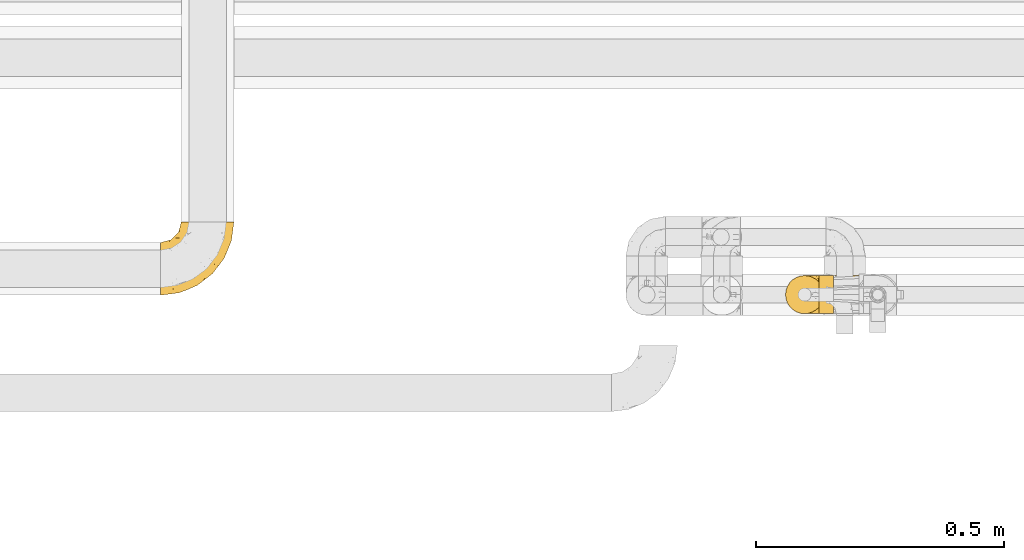
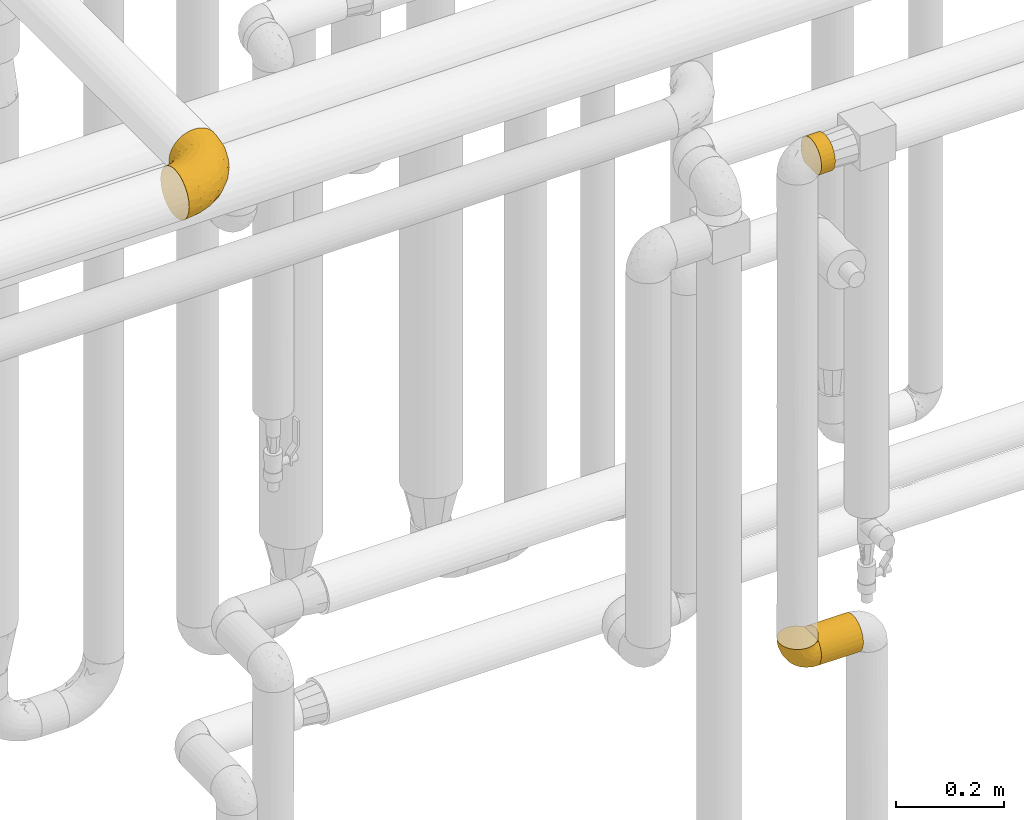
# One storey, part 441 of 827: 4 coverings.
"""IFC2X3 building model written with IfcOpenShell, lengths in millimetres."""

from ifc_helpers import new_model, entity, si_unit, converted_unit, derived_unit, direction, frame, origin, place, context, subcontext, project, spatial, faceted_brep, element, save


model = new_model("IFC2X3")

# Units and contexts
model_context = context("Model", 3, precision=0.01, world=origin(), true_north=direction((6.12303176911189e-17, 1.0)))
body_context = subcontext(model_context, "Body", "Model", "MODEL_VIEW")
ifc_project = project(units=[si_unit("LENGTHUNIT", "METRE", prefix="MILLI"), si_unit("AREAUNIT", "SQUARE_METRE"), si_unit("VOLUMEUNIT", "CUBIC_METRE"), converted_unit("PLANEANGLEUNIT", "DEGREE", entity("IfcRatioMeasure", 0.0174532925199433), si_unit("PLANEANGLEUNIT", "RADIAN"), dimensions=[0, 0, 0, 0, 0, 0, 0]), si_unit("MASSUNIT", "GRAM", prefix="KILO"), derived_unit("MASSDENSITYUNIT", [(si_unit("MASSUNIT", "GRAM", prefix="KILO"), 1), (si_unit("LENGTHUNIT", "METRE"), -3)]), derived_unit("MOMENTOFINERTIAUNIT", [(si_unit("LENGTHUNIT", "METRE"), 4)]), si_unit("TIMEUNIT", "SECOND"), si_unit("FREQUENCYUNIT", "HERTZ"), si_unit("THERMODYNAMICTEMPERATUREUNIT", "DEGREE_CELSIUS"), derived_unit("THERMALTRANSMITTANCEUNIT", [(si_unit("MASSUNIT", "GRAM", prefix="KILO"), 1), (si_unit("THERMODYNAMICTEMPERATUREUNIT", "KELVIN"), -1), (si_unit("TIMEUNIT", "SECOND"), -3)]), derived_unit("VOLUMETRICFLOWRATEUNIT", [(si_unit("LENGTHUNIT", "METRE"), 3), (si_unit("TIMEUNIT", "SECOND"), -1)]), derived_unit("MASSFLOWRATEUNIT", [(si_unit("MASSUNIT", "GRAM", prefix="KILO"), 1), (si_unit("TIMEUNIT", "SECOND"), -1)]), derived_unit("ROTATIONALFREQUENCYUNIT", [(si_unit("TIMEUNIT", "SECOND"), -1)]), si_unit("ELECTRICCURRENTUNIT", "AMPERE"), si_unit("ELECTRICVOLTAGEUNIT", "VOLT"), si_unit("POWERUNIT", "WATT"), si_unit("FORCEUNIT", "NEWTON", prefix="KILO"), si_unit("ILLUMINANCEUNIT", "LUX"), si_unit("LUMINOUSFLUXUNIT", "LUMEN"), si_unit("LUMINOUSINTENSITYUNIT", "CANDELA"), derived_unit("USERDEFINED", [(si_unit("MASSUNIT", "GRAM", prefix="KILO"), -1), (si_unit("LENGTHUNIT", "METRE"), -2), (si_unit("TIMEUNIT", "SECOND"), 3), (si_unit("LUMINOUSFLUXUNIT", "LUMEN"), 1)]), derived_unit("LINEARVELOCITYUNIT", [(si_unit("LENGTHUNIT", "METRE"), 1), (si_unit("TIMEUNIT", "SECOND"), -1)]), si_unit("PRESSUREUNIT", "PASCAL"), derived_unit("USERDEFINED", [(si_unit("LENGTHUNIT", "METRE"), -2), (si_unit("MASSUNIT", "GRAM", prefix="KILO"), 1), (si_unit("TIMEUNIT", "SECOND"), -2)]), derived_unit("LINEARFORCEUNIT", [(si_unit("MASSUNIT", "GRAM", prefix="KILO"), 1), (si_unit("LENGTHUNIT", "METRE"), 1), (si_unit("TIMEUNIT", "SECOND"), -2), (si_unit("LENGTHUNIT", "METRE"), -1)]), derived_unit("PLANARFORCEUNIT", [(si_unit("MASSUNIT", "GRAM", prefix="KILO"), 1), (si_unit("LENGTHUNIT", "METRE"), 1), (si_unit("TIMEUNIT", "SECOND"), -2), (si_unit("LENGTHUNIT", "METRE"), -2)])], contexts=[model_context])

# Site, building, storey
site_placement = place(None, origin())
site = spatial("IfcSite", under=ifc_project, at=site_placement, CompositionType="ELEMENT")
building_placement = place(site_placement, origin())
building = spatial("IfcBuilding", under=site, at=building_placement, CompositionType="ELEMENT")
storey_placement = place(building_placement, frame((0.0, 0.0, 28200.0)))
storey = spatial("IfcBuildingStorey", under=building, at=storey_placement, Name="08", CompositionType="ELEMENT", Elevation=28200.0)

# Coverings
covering_1_placement = place(storey_placement, frame((59220.14, 15404.21, 2660.0)))
element("IfcCovering", 1, at=covering_1_placement, inside=storey, Name=":ADSK_", ObjectType=":ADSK_", PredefinedType="INSULATION", context=body_context, shape_type="Brep", body=[
    faceted_brep([(31.32, 73.25, 20.8), (31.32, 77.09, 30.06), (31.32, 78.4, 40.0), (31.32, 77.09, 49.93), (31.32, 73.25, 59.2), (31.32, 67.15, 67.15), (31.32, 59.2, 73.25), (31.32, 49.93, 77.09), (31.32, 40.0, 78.4), (31.32, 30.06, 77.09), (31.32, 20.8, 73.25), (31.32, 12.84, 67.15), (31.32, 6.74, 59.2), (31.32, 2.9, 49.93), (31.32, 1.6, 40.0), (31.32, 2.9, 30.06), (31.32, 6.74, 20.8), (31.32, 12.84, 12.84), (31.32, 20.8, 6.74), (31.32, 30.06, 2.9), (31.32, 40.0, 1.6), (31.32, 49.93, 2.9), (31.32, 59.2, 6.74), (31.32, 67.15, 12.84), (1.6, 77.09, 49.93), (1.6, 78.4, 40.0), (1.6, 77.51, 31.79), (1.6, 74.9, 23.98), (1.6, 70.68, 16.91), (1.6, 65.05, 10.9), (1.6, 14.94, 10.9), (1.6, 9.31, 16.91), (1.6, 5.09, 23.98), (1.6, 2.48, 31.79), (1.6, 1.6, 40.0), (1.6, 2.9, 49.93), (1.6, 6.74, 59.2), (1.6, 12.84, 67.15), (1.6, 20.8, 73.25), (1.6, 30.06, 77.09), (1.6, 40.0, 78.4), (1.6, 49.93, 77.09), (1.6, 59.2, 73.25), (1.6, 67.15, 67.15), (1.6, 73.25, 59.2), (5.57, 20.48, 6.92), (8.5, 26.63, 4.0), (10.29, 33.21, 2.2), (10.9, 40.0, 1.6), (10.29, 46.78, 2.2), (8.5, 53.36, 4.0), (5.57, 59.51, 6.92)], [[[0, 1, 2, 3, 4, 5, 6, 7, 8, 9, 10, 11, 12, 13, 14, 15, 16, 17, 18, 19, 20, 21, 22, 23]], [[24, 25, 26, 27, 28, 29, 30, 31, 32, 33, 34, 35, 36, 37, 38, 39, 40, 41, 42, 43, 44]], [[14, 34, 33]], [[33, 32, 15]], [[31, 16, 32]], [[14, 33, 15]], [[16, 15, 32]], [[17, 16, 31]], [[31, 30, 17]], [[45, 18, 17]], [[46, 47, 19]], [[45, 46, 18]], [[18, 46, 19]], [[20, 19, 47]], [[48, 20, 47]], [[45, 17, 30]], [[49, 50, 21]], [[22, 51, 23]], [[50, 51, 22]], [[48, 49, 20]], [[20, 49, 21]], [[50, 22, 21]], [[51, 29, 23]], [[0, 28, 27]], [[26, 25, 2]], [[1, 27, 26]], [[23, 28, 0]], [[2, 1, 26]], [[27, 1, 0]], [[28, 23, 29]], [[2, 25, 24, 3]], [[3, 24, 44, 4]], [[4, 44, 43, 5]], [[6, 42, 41, 7]], [[7, 41, 40, 8]], [[5, 43, 42, 6]], [[8, 40, 39, 9]], [[9, 39, 38, 10]], [[10, 38, 37, 11]], [[12, 36, 35, 13]], [[13, 35, 34, 14]], [[11, 37, 36, 12]], [[29, 51, 50, 49, 48, 47, 46, 45, 30]]]),
])
covering_2_placement = place(storey_placement, frame((59220.14, 15404.21, 1553.05)))
element("IfcCovering", 2, at=covering_2_placement, inside=storey, Name=":ADSK_", ObjectType=":ADSK_", PredefinedType="INSULATION", context=body_context, shape_type="Brep", body=[
    faceted_brep([(1.6, 20.8, 6.74), (1.6, 12.84, 12.84), (1.6, 6.74, 20.8), (1.6, 2.9, 30.06), (1.6, 1.6, 40.0), (1.6, 2.48, 48.2), (1.6, 5.09, 56.01), (1.6, 9.31, 63.08), (1.6, 14.94, 69.1), (1.6, 65.05, 69.1), (1.6, 70.68, 63.08), (1.6, 74.9, 56.01), (1.6, 77.51, 48.2), (1.6, 78.4, 40.0), (1.6, 77.09, 30.06), (1.6, 73.25, 20.8), (1.6, 67.15, 12.84), (1.6, 59.2, 6.74), (1.6, 49.93, 2.9), (1.6, 40.0, 1.6), (1.6, 30.06, 2.9), (91.22, 2.9, 49.93), (91.22, 1.6, 40.0), (91.22, 2.48, 31.79), (91.22, 5.09, 23.98), (91.22, 9.31, 16.91), (91.22, 14.94, 10.9), (91.22, 65.05, 10.9), (91.22, 70.68, 16.91), (91.22, 74.9, 23.98), (91.22, 77.51, 31.79), (91.22, 78.4, 40.0), (91.22, 77.09, 49.93), (91.22, 73.25, 59.2), (91.22, 67.15, 67.15), (91.22, 59.2, 73.25), (91.22, 49.93, 77.09), (91.22, 40.0, 78.4), (91.22, 30.06, 77.09), (91.22, 20.8, 73.25), (91.22, 12.84, 67.15), (91.22, 6.74, 59.2), (87.25, 59.51, 6.92), (84.32, 53.36, 4.0), (82.52, 46.78, 2.2), (81.92, 40.0, 1.6), (82.52, 33.21, 2.2), (84.32, 26.63, 4.0), (87.25, 20.48, 6.92), (8.5, 26.63, 76.0), (10.29, 33.21, 77.79), (10.9, 40.0, 78.4), (5.57, 20.48, 73.07), (10.29, 46.78, 77.79), (8.5, 53.36, 76.0), (5.57, 59.51, 73.07)], [[[0, 1, 2, 3, 4, 5, 6, 7, 8, 9, 10, 11, 12, 13, 14, 15, 16, 17, 18, 19, 20]], [[21, 22, 23, 24, 25, 26, 27, 28, 29, 30, 31, 32, 33, 34, 35, 36, 37, 38, 39, 40, 41]], [[31, 30, 13]], [[29, 28, 15]], [[30, 29, 14]], [[14, 13, 30]], [[15, 14, 29]], [[28, 16, 15]], [[28, 27, 16]], [[27, 42, 17]], [[43, 44, 18]], [[42, 43, 17]], [[17, 43, 18]], [[19, 18, 44]], [[45, 19, 44]], [[27, 17, 16]], [[46, 47, 20]], [[48, 26, 0]], [[47, 48, 0]], [[45, 46, 19]], [[19, 46, 20]], [[47, 0, 20]], [[26, 1, 0]], [[2, 25, 24]], [[3, 24, 23]], [[4, 23, 22]], [[1, 25, 2]], [[2, 24, 3]], [[23, 4, 3]], [[25, 1, 26]], [[5, 22, 21]], [[6, 21, 41]], [[7, 41, 40]], [[4, 22, 5]], [[5, 21, 6]], [[41, 7, 6]], [[40, 8, 7]], [[49, 39, 38]], [[38, 37, 50]], [[51, 50, 37]], [[52, 8, 39]], [[50, 49, 38]], [[52, 39, 49]], [[39, 8, 40]], [[53, 51, 37]], [[53, 37, 36]], [[54, 36, 35]], [[54, 53, 36]], [[9, 55, 35]], [[54, 35, 55]], [[35, 34, 9]], [[10, 34, 33]], [[11, 33, 32]], [[12, 32, 31]], [[10, 33, 11]], [[11, 32, 12]], [[31, 13, 12]], [[34, 10, 9]], [[8, 52, 49, 50, 51, 53, 54, 55, 9]], [[44, 43, 42, 27, 26, 48, 47, 46, 45]]]),
])
covering_3_placement = place(storey_placement, frame((59152.59, 15404.16, 1553.0)))
element("IfcCovering", 3, at=covering_3_placement, inside=storey, Name=":ADSK_", ObjectType=":ADSK_", PredefinedType="INSULATION", context=body_context, shape_type="Brep", body=[
    faceted_brep([(23.36, 74.68, 69.15), (16.07, 70.1, 69.15), (9.98, 64.01, 69.15), (5.4, 56.72, 69.15), (2.56, 48.6, 69.15), (1.6, 40.05, 69.15), (2.56, 31.49, 69.15), (5.41, 23.36, 69.15), (9.99, 16.07, 69.15), (16.08, 9.98, 69.15), (23.37, 5.4, 69.15), (31.49, 2.56, 69.15), (40.05, 1.6, 69.15), (48.15, 2.46, 69.15), (55.88, 5.01, 69.15), (62.9, 9.13, 69.15), (68.89, 14.62, 69.15), (68.89, 16.82, 69.15), (68.89, 18.56, 69.15), (68.89, 20.52, 69.15), (68.89, 22.49, 69.15), (68.89, 24.46, 69.15), (68.89, 26.42, 69.15), (68.89, 28.39, 69.15), (68.89, 30.36, 69.15), (68.89, 32.55, 69.15), (68.89, 34.75, 69.15), (68.89, 36.94, 69.15), (68.89, 39.13, 69.15), (68.89, 41.33, 69.15), (68.89, 43.52, 69.15), (68.89, 45.72, 69.15), (68.89, 47.91, 69.15), (68.89, 50.11, 69.15), (68.89, 52.3, 69.15), (68.89, 54.49, 69.15), (68.89, 56.69, 69.15), (68.89, 58.88, 69.15), (68.89, 61.08, 69.15), (68.89, 63.27, 69.15), (68.89, 65.47, 69.15), (62.89, 70.97, 69.15), (55.86, 75.09, 69.15), (48.13, 77.64, 69.15), (40.05, 78.5, 69.15), (31.49, 77.53, 69.15), (69.15, 14.62, 68.89), (69.15, 9.12, 62.89), (69.15, 5.0, 55.87), (69.15, 2.46, 48.14), (69.15, 1.6, 40.05), (69.15, 2.91, 30.09), (69.15, 6.75, 20.82), (69.15, 12.86, 12.86), (69.15, 20.82, 6.75), (69.15, 30.09, 2.91), (69.15, 40.05, 1.6), (69.15, 50.0, 2.91), (69.15, 59.27, 6.75), (69.15, 67.23, 12.86), (69.15, 73.34, 20.82), (69.15, 77.19, 30.09), (69.15, 78.5, 40.05), (69.15, 77.63, 48.14), (69.15, 75.09, 55.87), (69.15, 70.97, 62.89), (69.15, 65.47, 68.89), (69.15, 63.27, 68.89), (69.15, 62.29, 68.89), (69.15, 60.7, 68.89), (69.15, 59.11, 68.89), (69.15, 57.52, 68.89), (69.15, 55.93, 68.89), (69.15, 54.34, 68.89), (69.15, 52.76, 68.89), (69.15, 51.17, 68.89), (69.15, 49.58, 68.89), (69.15, 47.99, 68.89), (69.15, 46.4, 68.89), (69.15, 44.81, 68.89), (69.15, 43.22, 68.89), (69.15, 41.63, 68.89), (69.15, 40.05, 68.89), (69.15, 38.46, 68.89), (69.15, 36.87, 68.89), (69.15, 35.28, 68.89), (69.15, 33.69, 68.89), (69.15, 32.1, 68.89), (69.15, 30.51, 68.89), (69.15, 28.92, 68.89), (69.15, 27.33, 68.89), (69.15, 25.37, 68.89), (69.15, 23.4, 68.89), (69.15, 21.21, 68.89), (69.15, 19.01, 68.89), (69.15, 16.82, 68.89), (68.96, 42.32, 68.97), (68.97, 44.02, 68.96), (68.97, 47.13, 68.97), (68.97, 48.74, 68.97), (68.95, 23.57, 68.98), (68.96, 25.13, 68.97), (68.98, 61.34, 68.96), (68.97, 22.02, 68.96), (68.97, 29.72, 68.96), (68.98, 56.73, 68.96), (68.97, 55.14, 68.96), (68.97, 37.66, 68.96), (68.94, 64.12, 69.0), (68.98, 28.13, 68.96), (68.98, 26.62, 68.96), (68.96, 31.46, 68.97), (68.97, 16.16, 68.96), (68.98, 39.16, 68.96), (68.98, 50.37, 68.96), (68.97, 17.69, 68.97), (68.96, 19.17, 68.97), (68.97, 62.78, 68.97), (68.97, 58.35, 68.96), (68.98, 45.53, 68.96), (68.96, 59.91, 68.97), (68.97, 65.47, 68.97), (68.94, 65.47, 69.02), (68.92, 65.47, 69.08), (68.97, 14.62, 68.97), (69.02, 14.62, 68.94), (69.08, 14.62, 68.92), (68.98, 20.59, 68.96), (68.97, 32.99, 68.96), (68.98, 34.48, 68.95), (68.97, 51.91, 68.96), (69.08, 65.47, 68.92), (69.02, 65.47, 68.94), (68.96, 53.48, 68.98), (68.92, 14.62, 69.08), (68.94, 14.62, 69.02), (68.97, 40.77, 68.96), (68.96, 35.97, 68.97), (67.02, 7.84, 61.33), (63.33, 3.53, 53.1), (64.61, 8.32, 63.33), (49.27, 1.6, 49.27), (51.4, 2.19, 55.53), (43.94, 1.6, 54.6), (61.87, 1.6, 41.99), (61.54, 4.57, 57.07), (57.95, 3.96, 57.95), (56.12, 2.28, 51.56), (63.4, 1.6, 41.58), (65.41, 7.69, 61.7), (53.1, 3.53, 63.33), (63.04, 8.32, 65.0), (61.33, 7.84, 67.02), (41.99, 1.6, 61.87), (54.6, 1.6, 43.94), (56.6, 4.34, 61.21), (41.58, 1.6, 63.4), (13.72, 29.63, 33.11), (5.82, 27.34, 52.82), (6.74, 40.05, 43.3), (58.82, 2.39, 33.73), (51.58, 2.43, 36.52), (42.09, 9.07, 24.87), (46.12, 16.64, 14.17), (55.56, 9.54, 18.43), (52.38, 4.52, 28.67), (61.54, 4.52, 26.0), (23.76, 7.49, 49.25), (20.5, 7.49, 59.72), (14.64, 12.85, 55.1), (41.77, 2.35, 44.72), (16.28, 22.66, 34.15), (49.4, 32.9, 5.25), (52.34, 25.33, 6.75), (4.3, 40.05, 55.54), (58.67, 16.64, 10.47), (25.26, 19.99, 25.49), (20.17, 16.37, 35.53), (34.7, 3.26, 48.22), (28.67, 3.75, 58.71), (8.62, 19.58, 57.42), (33.37, 7.5, 34.84), (41.35, 4.04, 36.87), (17.15, 13.94, 45.01), (12.68, 19.58, 44.4), (21.47, 28.21, 23.96), (41.11, 24.75, 11.2), (37.53, 31.42, 10.56), (30.64, 26.2, 16.81), (26.66, 33.36, 17.38), (21.38, 40.05, 21.38), (14.06, 40.05, 32.34), (55.54, 40.05, 4.3), (35.17, 16.14, 20.65), (29.04, 12.85, 29.66), (24.34, 10.47, 39.6), (29.33, 6.49, 42.55), (43.3, 40.05, 6.74), (32.34, 40.05, 14.06), (57.75, 75.57, 26.84), (49.41, 47.37, 5.28), (27.85, 52.91, 18.52), (13.7, 50.46, 33.13), (14.63, 67.23, 55.1), (8.61, 60.5, 57.43), (48.85, 70.55, 20.72), (54.13, 63.45, 11.46), (37.84, 62.61, 17.69), (23.75, 72.6, 49.26), (20.49, 72.6, 59.73), (28.66, 76.34, 58.71), (20.83, 59.34, 29.72), (55.15, 77.76, 35.35), (54.6, 78.5, 43.94), (61.87, 78.5, 41.99), (41.58, 78.5, 63.4), (57.58, 53.16, 4.93), (59.91, 70.55, 17.46), (36.94, 48.88, 10.94), (45.72, 54.76, 8.92), (5.82, 52.74, 52.83), (37.91, 71.93, 29.34), (50.18, 75.79, 30.26), (12.67, 60.5, 44.4), (49.29, 77.86, 39.06), (42.64, 77.64, 43.06), (43.94, 78.5, 54.6), (49.27, 78.5, 49.27), (19.45, 67.23, 42.69), (34.7, 76.82, 48.2), (41.99, 78.5, 61.87), (62.29, 77.8, 33.44), (29.01, 67.23, 29.67), (31.47, 73.2, 38.5), (37.18, 67.66, 23.35), (43.45, 75.99, 34.97), (63.33, 76.57, 53.1), (67.23, 73.21, 59.68), (66.07, 71.93, 62.19), (65.22, 71.07, 64.11), (61.99, 75.09, 57.97), (57.95, 76.13, 57.95), (53.09, 76.57, 63.33), (56.84, 77.69, 51.77), (61.33, 72.26, 67.02), (63.06, 71.77, 64.98), (51.41, 77.9, 55.53), (56.61, 75.75, 61.22)], [[[0, 1, 2, 3, 4, 5, 6, 7, 8, 9, 10, 11, 12, 13, 14, 15, 16, 17, 18, 19, 20, 21, 22, 23, 24, 25, 26, 27, 28, 29, 30, 31, 32, 33, 34, 35, 36, 37, 38, 39, 40, 41, 42, 43, 44, 45]], [[46, 47, 48, 49, 50, 51, 52, 53, 54, 55, 56, 57, 58, 59, 60, 61, 62, 63, 64, 65, 66, 67, 68, 69, 70, 71, 72, 73, 74, 75, 76, 77, 78, 79, 80, 81, 82, 83, 84, 85, 86, 87, 88, 89, 90, 91, 92, 93, 94, 95]], [[96, 97, 30]], [[98, 77, 99]], [[100, 101, 21]], [[69, 68, 102]], [[20, 19, 103]], [[24, 23, 104]], [[20, 103, 100]], [[72, 105, 106]], [[84, 83, 107]], [[89, 88, 104]], [[108, 67, 66]], [[109, 110, 90]], [[111, 25, 24]], [[112, 17, 16]], [[82, 113, 83]], [[109, 23, 22]], [[114, 76, 75]], [[105, 36, 106]], [[104, 111, 24]], [[18, 115, 116]], [[97, 96, 80]], [[67, 108, 117]], [[105, 71, 118]], [[31, 97, 119]], [[102, 120, 69]], [[108, 121, 122, 123, 40]], [[112, 95, 115]], [[17, 115, 18]], [[94, 116, 115]], [[117, 68, 67]], [[38, 117, 39]], [[112, 124, 125, 126, 46]], [[17, 112, 115]], [[70, 120, 118]], [[39, 117, 108]], [[120, 38, 37]], [[120, 37, 118]], [[120, 70, 69]], [[116, 94, 127]], [[128, 86, 129]], [[117, 38, 102]], [[74, 130, 75]], [[99, 33, 32]], [[115, 95, 94]], [[39, 108, 40]], [[108, 66, 131, 132, 121]], [[105, 72, 71]], [[118, 37, 36]], [[71, 70, 118]], [[35, 106, 36]], [[36, 105, 118]], [[35, 133, 106]], [[74, 73, 133]], [[106, 133, 73]], [[99, 114, 33]], [[133, 35, 34]], [[73, 72, 106]], [[95, 112, 46]], [[112, 16, 134, 135, 124]], [[130, 114, 75]], [[99, 76, 114]], [[114, 130, 33]], [[34, 33, 130]], [[78, 77, 98]], [[98, 119, 78]], [[130, 133, 34]], [[133, 130, 74]], [[79, 97, 80]], [[98, 99, 32]], [[98, 32, 31]], [[77, 76, 99]], [[97, 79, 119]], [[136, 96, 29]], [[30, 97, 31]], [[136, 29, 28]], [[81, 80, 96]], [[29, 96, 30]], [[31, 119, 98]], [[119, 79, 78]], [[96, 136, 81]], [[82, 81, 136]], [[113, 107, 83]], [[84, 107, 137]], [[107, 27, 137]], [[113, 28, 107]], [[27, 107, 28]], [[85, 84, 137]], [[137, 27, 26]], [[113, 136, 28]], [[136, 113, 82]], [[109, 89, 104]], [[86, 85, 129]], [[89, 109, 90]], [[111, 87, 128]], [[26, 129, 137]], [[88, 111, 104]], [[25, 111, 128]], [[22, 110, 109]], [[23, 109, 104]], [[110, 91, 90]], [[100, 92, 101]], [[110, 22, 101]], [[91, 110, 101]], [[116, 19, 18]], [[111, 88, 87]], [[127, 103, 19]], [[25, 128, 26]], [[86, 128, 87]], [[128, 129, 26]], [[137, 129, 85]], [[120, 102, 38]], [[117, 102, 68]], [[91, 101, 92]], [[21, 101, 22]], [[93, 92, 103]], [[100, 21, 20]], [[100, 103, 92]], [[127, 93, 103]], [[93, 127, 94]], [[116, 127, 19]], [[126, 138, 47]], [[48, 138, 139]], [[140, 125, 124]], [[141, 142, 143]], [[144, 49, 139]], [[145, 140, 146]], [[48, 139, 49]], [[139, 145, 147]], [[49, 144, 148, 50]], [[126, 125, 149]], [[14, 13, 150]], [[151, 146, 140]], [[149, 140, 145]], [[152, 151, 135]], [[152, 14, 150]], [[16, 15, 134]], [[13, 153, 150]], [[124, 151, 140]], [[141, 147, 142]], [[14, 152, 15]], [[15, 152, 134]], [[47, 46, 126]], [[139, 154, 144]], [[138, 48, 47]], [[125, 140, 149]], [[135, 134, 152]], [[146, 155, 142]], [[145, 146, 147]], [[149, 139, 138]], [[147, 141, 154]], [[147, 146, 142]], [[139, 147, 154]], [[139, 149, 145]], [[149, 138, 126]], [[155, 146, 151]], [[150, 143, 142]], [[152, 155, 151]], [[150, 142, 155]], [[13, 12, 156, 153]], [[153, 143, 150]], [[152, 150, 155]], [[151, 124, 135]], [[157, 158, 159]], [[160, 154, 161]], [[162, 163, 164]], [[165, 166, 160]], [[167, 168, 169]], [[141, 170, 161]], [[156, 12, 11]], [[158, 157, 171]], [[172, 55, 173]], [[158, 6, 174]], [[175, 54, 53]], [[52, 166, 164]], [[52, 164, 53]], [[54, 175, 173]], [[166, 52, 51]], [[176, 177, 171]], [[178, 143, 179]], [[156, 11, 179]], [[8, 7, 180]], [[169, 9, 8]], [[179, 143, 153, 156]], [[179, 11, 10]], [[168, 179, 10]], [[181, 162, 182]], [[179, 167, 178]], [[183, 184, 177]], [[183, 169, 184]], [[176, 171, 185]], [[172, 186, 187]], [[158, 7, 6]], [[159, 158, 174]], [[184, 180, 158]], [[54, 173, 55]], [[180, 169, 8]], [[188, 189, 187]], [[9, 168, 10]], [[186, 188, 187]], [[190, 157, 159, 191]], [[55, 172, 192]], [[176, 193, 194]], [[161, 170, 182]], [[162, 164, 165]], [[175, 164, 163]], [[51, 50, 148]], [[167, 195, 196]], [[178, 182, 170]], [[6, 5, 174]], [[158, 180, 7]], [[169, 180, 184]], [[169, 168, 9]], [[179, 168, 167]], [[182, 162, 165]], [[162, 194, 193]], [[161, 165, 160]], [[195, 181, 196]], [[192, 172, 197]], [[192, 56, 55]], [[189, 190, 198]], [[198, 197, 187]], [[172, 187, 197]], [[185, 189, 188]], [[198, 187, 189]], [[186, 172, 173]], [[173, 163, 186]], [[193, 186, 163]], [[176, 185, 188]], [[185, 157, 190]], [[188, 186, 193]], [[177, 176, 194]], [[188, 193, 176]], [[162, 193, 163]], [[195, 177, 194]], [[171, 177, 184]], [[181, 195, 194]], [[183, 167, 169]], [[162, 181, 194]], [[196, 182, 178]], [[158, 171, 184]], [[171, 157, 185]], [[177, 195, 183]], [[167, 183, 195]], [[182, 196, 181]], [[178, 170, 143]], [[178, 167, 196]], [[164, 175, 53]], [[173, 175, 163]], [[160, 51, 148]], [[164, 166, 165]], [[51, 160, 166]], [[160, 148, 144, 154]], [[141, 161, 154]], [[182, 165, 161]], [[190, 189, 185]], [[143, 170, 141]], [[60, 199, 61]], [[197, 200, 192]], [[201, 190, 202]], [[200, 57, 192]], [[203, 204, 2]], [[205, 206, 207]], [[208, 209, 210]], [[211, 207, 201]], [[212, 213, 214]], [[45, 215, 210]], [[216, 206, 58]], [[45, 44, 215]], [[59, 217, 60]], [[60, 217, 199]], [[0, 45, 210]], [[218, 201, 219]], [[202, 159, 220]], [[205, 221, 222]], [[223, 204, 203]], [[1, 203, 2]], [[57, 200, 216]], [[220, 3, 204]], [[220, 174, 4]], [[1, 0, 209]], [[212, 224, 213]], [[225, 226, 227]], [[228, 223, 203]], [[208, 210, 229]], [[210, 226, 229]], [[3, 220, 4]], [[58, 206, 59]], [[209, 203, 1]], [[202, 220, 223]], [[228, 203, 208]], [[202, 211, 201]], [[3, 2, 204]], [[202, 190, 191, 159]], [[210, 215, 230, 226]], [[199, 212, 231]], [[232, 233, 221]], [[233, 208, 229]], [[207, 206, 219]], [[217, 206, 205]], [[227, 224, 225]], [[233, 232, 228]], [[201, 207, 219]], [[234, 232, 221]], [[218, 219, 200]], [[202, 223, 211]], [[174, 220, 159]], [[174, 5, 4]], [[61, 231, 62]], [[220, 204, 223]], [[210, 209, 0]], [[203, 209, 208]], [[225, 233, 229]], [[224, 227, 213]], [[221, 233, 235]], [[57, 56, 192]], [[198, 218, 197]], [[200, 219, 216]], [[201, 198, 190]], [[197, 218, 200]], [[198, 201, 218]], [[206, 216, 219]], [[58, 57, 216]], [[231, 212, 214]], [[222, 212, 199]], [[228, 211, 223]], [[207, 211, 232]], [[62, 231, 214]], [[199, 231, 61]], [[233, 228, 208]], [[211, 228, 232]], [[222, 221, 235]], [[234, 205, 207]], [[206, 217, 59]], [[199, 217, 205]], [[205, 222, 199]], [[224, 222, 235]], [[222, 224, 212]], [[224, 235, 225]], [[233, 225, 235]], [[226, 225, 229]], [[205, 234, 221]], [[207, 232, 234]], [[63, 214, 236]], [[214, 213, 236]], [[214, 63, 62]], [[237, 236, 238]], [[238, 132, 131]], [[236, 237, 64]], [[239, 240, 241]], [[63, 236, 64]], [[131, 66, 65]], [[237, 131, 65]], [[242, 230, 43]], [[237, 65, 64]], [[239, 121, 132]], [[42, 242, 43]], [[241, 240, 243]], [[41, 123, 244]], [[43, 230, 215, 44]], [[244, 122, 245]], [[227, 246, 243]], [[241, 247, 245]], [[121, 239, 245]], [[41, 40, 123]], [[132, 238, 239]], [[244, 42, 41]], [[131, 237, 238]], [[240, 239, 238]], [[245, 239, 241]], [[247, 241, 246]], [[247, 244, 245]], [[238, 236, 240]], [[243, 236, 213]], [[236, 243, 240]], [[227, 226, 246]], [[243, 213, 227]], [[242, 246, 226]], [[243, 246, 241]], [[246, 242, 247]], [[244, 247, 242]], [[242, 226, 230]], [[42, 244, 242]], [[122, 244, 123]], [[122, 121, 245]]]),
])
covering_4_placement = place(storey_placement, frame((57891.29, 15441.56, 2995.35)))
element("IfcCovering", 4, at=covering_4_placement, inside=storey, Name=":ADSK_", ObjectType=":ADSK_", PredefinedType="INSULATION", context=body_context, shape_type="Brep", body=[
    faceted_brep([(148.32, 149.65, 66.44), (149.65, 149.65, 54.65), (148.31, 149.65, 42.84), (144.39, 149.65, 31.62), (138.06, 149.65, 21.56), (129.66, 149.65, 13.16), (119.6, 149.65, 6.84), (108.39, 149.65, 2.92), (96.6, 149.65, 1.6), (84.79, 149.65, 2.93), (73.57, 149.65, 6.85), (63.51, 149.65, 13.18), (55.11, 149.65, 21.58), (48.79, 149.65, 31.64), (44.87, 149.65, 42.85), (43.55, 149.65, 54.65), (44.88, 149.65, 66.46), (48.8, 149.65, 77.67), (55.13, 149.65, 87.73), (63.53, 149.65, 96.13), (73.59, 149.65, 102.45), (84.8, 149.65, 106.37), (96.6, 149.65, 107.7), (108.41, 149.65, 106.36), (119.62, 149.65, 102.44), (129.68, 149.65, 96.11), (138.08, 149.65, 87.71), (144.4, 149.65, 77.65), (1.6, 105.89, 40.91), (1.6, 100.59, 28.12), (1.6, 92.16, 17.13), (1.6, 81.17, 8.7), (1.6, 68.38, 3.4), (1.6, 54.65, 1.6), (1.6, 40.91, 3.4), (1.6, 28.12, 8.7), (1.6, 17.13, 17.13), (1.6, 8.7, 28.12), (1.6, 3.4, 40.91), (1.6, 1.6, 54.65), (1.6, 3.4, 68.38), (1.6, 8.7, 81.17), (1.6, 17.13, 92.16), (1.6, 28.12, 100.59), (1.6, 40.91, 105.89), (1.6, 54.65, 107.7), (1.6, 68.38, 105.89), (1.6, 81.17, 100.59), (1.6, 92.16, 92.16), (1.6, 100.59, 81.17), (1.6, 105.89, 68.38), (1.6, 107.7, 54.65), (27.97, 14.05, 85.53), (37.09, 9.45, 73.42), (58.27, 22.36, 83.77), (27.13, 4.7, 64.22), (39.91, 6.64, 54.65), (109.11, 81.47, 96.72), (94.41, 56.83, 93.36), (110.94, 64.02, 84.47), (89.69, 34.04, 71.37), (75.62, 21.43, 54.65), (106.28, 44.96, 54.65), (60.12, 49.8, 103.47), (41.41, 35.43, 100.91), (63.22, 42.1, 99.1), (32.05, 43.59, 105.43), (52.13, 57.88, 106.79), (123.27, 91.8, 89.81), (129.32, 88.01, 79.59), (138.3, 115.65, 81.29), (62.95, 18.94, 74.01), (55.89, 12.83, 64.14), (37.4, 24.96, 94.75), (144.6, 111.33, 54.65), (142.66, 113.8, 70.74), (117.85, 60.89, 68.3), (134.01, 86.24, 66.05), (89.25, 65.84, 100.73), (103.34, 124.58, 106.78), (113.52, 121.36, 103.6), (57.43, 72.79, 107.7), (44.19, 66.04, 107.7), (30.95, 59.29, 107.7), (77.98, 73.26, 106.07), (132.66, 121.69, 90.59), (121.52, 109.82, 97.43), (86.93, 40.11, 84.51), (68.4, 36.57, 93.3), (78.45, 93.81, 107.7), (67.94, 83.3, 107.7), (94.53, 136.6, 107.7), (91.95, 120.29, 107.7), (93.36, 99.11, 106.79), (85.2, 107.05, 107.7), (101.45, 91.12, 103.47), (129.81, 75.62, 54.65), (16.27, 56.97, 107.7), (42.46, 126.65, 76.99), (40.4, 116.55, 84.28), (49.71, 120.09, 91.11), (39.4, 76.06, 106.26), (31.26, 83.69, 102.6), (27.7, 71.88, 106.08), (16.7, 66.92, 106.56), (70.67, 110.43, 105.36), (81.69, 121.31, 106.74), (16.68, 81.0, 101.59), (22.57, 113.32, 54.65), (14.26, 111.09, 54.65), (17.68, 109.14, 67.71), (19.58, 95.86, 91.36), (33.49, 99.07, 94.33), (33.01, 106.92, 87.1), (40.69, 131.39, 65.84), (40.15, 136.98, 54.65), (37.93, 128.67, 54.65), (31.04, 117.07, 68.92), (45.29, 96.39, 100.82), (23.55, 106.61, 79.83), (11.36, 103.72, 77.13), (59.1, 92.14, 105.9), (57.42, 107.13, 101.53), (68.96, 98.03, 106.72), (20.38, 88.38, 97.75), (72.46, 130.66, 103.08), (83.66, 135.45, 106.39), (60.66, 123.57, 98.1), (61.01, 137.75, 95.02), (51.85, 133.2, 86.9), (46.07, 138.8, 74.42), (30.25, 120.99, 54.65), (46.65, 84.53, 105.28), (43.0, 108.72, 92.87), (19.58, 95.86, 17.93), (72.44, 130.67, 6.22), (17.67, 109.13, 41.58), (78.45, 93.81, 1.6), (68.97, 98.02, 2.57), (70.65, 110.43, 3.94), (40.69, 131.4, 43.46), (42.45, 126.66, 32.32), (31.04, 117.08, 40.38), (42.99, 108.74, 16.44), (45.18, 96.31, 8.47), (33.46, 99.11, 15.01), (60.64, 123.58, 11.21), (57.37, 107.12, 7.78), (57.43, 72.79, 1.6), (44.19, 66.04, 1.6), (39.35, 76.07, 3.04), (16.27, 56.97, 1.6), (16.7, 66.92, 2.73), (91.95, 120.29, 1.6), (85.2, 107.05, 1.6), (81.68, 121.26, 2.55), (46.68, 84.46, 3.98), (31.26, 83.69, 6.69), (16.68, 81.0, 7.7), (27.7, 71.88, 3.21), (60.99, 137.76, 14.28), (51.84, 133.21, 22.42), (40.41, 116.58, 25.02), (49.72, 120.1, 18.18), (46.06, 138.81, 34.89), (94.53, 136.6, 1.6), (11.35, 103.72, 32.17), (33.02, 106.96, 22.23), (83.65, 135.44, 2.91), (20.38, 88.38, 11.54), (67.94, 83.3, 1.6), (23.53, 106.6, 29.46), (59.12, 92.12, 3.38), (30.95, 59.29, 1.6), (58.27, 22.36, 25.52), (27.97, 14.05, 23.76), (37.4, 24.96, 14.54), (41.41, 35.43, 8.38), (27.21, 4.71, 45.07), (37.09, 9.45, 35.87), (53.2, 11.79, 45.14), (52.13, 57.88, 2.5), (103.34, 124.57, 2.51), (113.5, 121.37, 5.68), (101.45, 91.12, 5.82), (94.41, 56.83, 15.93), (109.08, 81.48, 12.54), (110.95, 64.05, 24.81), (93.36, 99.11, 2.5), (77.98, 73.26, 3.22), (32.05, 43.59, 3.86), (64.63, 19.5, 35.85), (123.25, 91.8, 19.47), (132.65, 121.7, 18.68), (129.32, 88.04, 29.68), (139.96, 123.34, 27.95), (117.85, 60.89, 40.99), (89.69, 34.04, 37.92), (121.51, 109.85, 11.85), (63.23, 42.1, 10.19), (89.17, 65.78, 8.55), (142.66, 113.81, 38.53), (68.4, 36.57, 15.99), (86.94, 40.12, 24.79), (60.12, 49.8, 5.82), (133.2, 86.08, 40.56)], [[[0, 1, 2, 3, 4, 5, 6, 7, 8, 9, 10, 11, 12, 13, 14, 15, 16, 17, 18, 19, 20, 21, 22, 23, 24, 25, 26, 27]], [[28, 29, 30, 31, 32, 33, 34, 35, 36, 37, 38, 39, 40, 41, 42, 43, 44, 45, 46, 47, 48, 49, 50, 51]], [[52, 53, 54]], [[55, 39, 56]], [[57, 58, 59]], [[60, 61, 62]], [[63, 64, 65]], [[66, 63, 67]], [[68, 69, 70]], [[53, 71, 54]], [[41, 40, 53]], [[53, 72, 71]], [[73, 42, 52]], [[42, 41, 52]], [[74, 0, 75]], [[69, 76, 77]], [[43, 73, 64]], [[45, 44, 66]], [[57, 78, 58]], [[23, 79, 80]], [[67, 81, 82, 83]], [[67, 84, 81]], [[24, 23, 80]], [[25, 85, 26]], [[86, 85, 25]], [[42, 73, 43]], [[0, 27, 75]], [[25, 24, 86]], [[70, 26, 85]], [[0, 74, 1]], [[68, 85, 86]], [[66, 64, 63]], [[60, 59, 87]], [[54, 87, 88]], [[76, 60, 62]], [[84, 89, 90, 81]], [[79, 22, 91, 92]], [[77, 74, 75]], [[93, 92, 94, 89]], [[80, 86, 24]], [[40, 55, 53]], [[76, 59, 60]], [[93, 84, 95]], [[76, 62, 96]], [[55, 72, 53]], [[70, 27, 26]], [[75, 70, 69]], [[78, 84, 63]], [[93, 79, 92]], [[95, 86, 80]], [[77, 76, 96]], [[59, 69, 68]], [[57, 68, 86]], [[68, 57, 59]], [[59, 58, 87]], [[76, 69, 59]], [[88, 87, 58]], [[87, 54, 71]], [[86, 95, 57]], [[78, 57, 95]], [[84, 78, 95]], [[78, 63, 65]], [[58, 78, 65]], [[54, 88, 73]], [[84, 93, 89]], [[79, 95, 80]], [[79, 93, 95]], [[22, 79, 23]], [[66, 83, 97, 45]], [[84, 67, 63]], [[83, 66, 67]], [[64, 44, 43]], [[64, 66, 44]], [[65, 73, 88]], [[53, 52, 41]], [[73, 52, 54]], [[73, 65, 64]], [[65, 88, 58]], [[39, 55, 40]], [[72, 55, 56]], [[56, 61, 72]], [[60, 72, 61]], [[72, 60, 71]], [[87, 71, 60]], [[27, 70, 75]], [[68, 70, 85]], [[74, 77, 96]], [[69, 77, 75]], [[98, 99, 100]], [[46, 45, 97]], [[101, 102, 103]], [[103, 104, 83]], [[105, 94, 106]], [[107, 103, 102]], [[108, 109, 51, 110]], [[111, 112, 113]], [[114, 115, 116]], [[47, 104, 107]], [[110, 117, 108]], [[49, 48, 111]], [[102, 118, 112]], [[119, 120, 111]], [[50, 49, 120]], [[121, 122, 118]], [[105, 123, 89]], [[124, 48, 107]], [[20, 19, 125]], [[121, 81, 90]], [[117, 119, 99]], [[21, 20, 126]], [[22, 21, 91]], [[105, 125, 127]], [[110, 51, 50]], [[19, 128, 125]], [[16, 15, 115]], [[129, 98, 100]], [[126, 91, 21]], [[128, 129, 127]], [[122, 123, 105]], [[114, 117, 98]], [[17, 16, 130]], [[18, 128, 19]], [[129, 18, 17]], [[125, 106, 126]], [[115, 114, 16]], [[130, 129, 17]], [[114, 98, 130]], [[117, 116, 131, 108]], [[99, 119, 113]], [[122, 121, 123]], [[92, 126, 106]], [[105, 127, 122]], [[132, 121, 118]], [[114, 130, 16]], [[129, 130, 98]], [[50, 120, 110]], [[129, 128, 18]], [[125, 128, 127]], [[125, 126, 20]], [[91, 126, 92]], [[105, 89, 94]], [[105, 106, 125]], [[94, 92, 106]], [[100, 122, 127]], [[118, 122, 133]], [[112, 118, 133]], [[132, 118, 102]], [[132, 102, 101]], [[81, 121, 132]], [[82, 103, 83]], [[132, 101, 81]], [[104, 47, 46]], [[124, 107, 102]], [[48, 47, 107]], [[113, 112, 133]], [[112, 111, 124]], [[99, 113, 133]], [[111, 113, 119]], [[99, 133, 100]], [[117, 99, 98]], [[122, 100, 133]], [[127, 129, 100]], [[103, 82, 101]], [[81, 101, 82]], [[112, 124, 102]], [[48, 124, 111]], [[104, 103, 107]], [[46, 97, 104]], [[111, 120, 49]], [[83, 104, 97]], [[110, 120, 119]], [[117, 110, 119]], [[116, 117, 114]], [[89, 123, 90]], [[90, 123, 121]], [[30, 29, 134]], [[11, 10, 135]], [[51, 109, 108, 136]], [[137, 138, 139]], [[140, 141, 142]], [[143, 144, 145]], [[146, 139, 147]], [[148, 149, 150]], [[151, 32, 152]], [[153, 154, 155]], [[156, 150, 157]], [[158, 157, 159]], [[108, 142, 136]], [[31, 158, 152]], [[160, 161, 12]], [[162, 163, 143]], [[140, 142, 116]], [[142, 141, 162]], [[14, 164, 140]], [[14, 140, 115]], [[9, 8, 165]], [[160, 12, 11]], [[141, 164, 161]], [[13, 12, 161]], [[14, 115, 15]], [[28, 166, 29]], [[135, 139, 146]], [[141, 163, 162]], [[135, 146, 160]], [[143, 167, 162]], [[29, 166, 134]], [[116, 142, 108, 131]], [[165, 153, 168]], [[10, 9, 168]], [[168, 135, 10]], [[138, 147, 139]], [[158, 169, 157]], [[14, 13, 164]], [[116, 115, 140]], [[145, 167, 143]], [[135, 160, 11]], [[168, 153, 155]], [[138, 137, 170]], [[157, 144, 156]], [[147, 144, 143]], [[161, 164, 13]], [[140, 164, 141]], [[142, 171, 136]], [[136, 171, 166]], [[161, 160, 146]], [[165, 168, 9]], [[155, 139, 135]], [[139, 154, 137]], [[168, 155, 135]], [[139, 155, 154]], [[144, 147, 172]], [[163, 147, 143]], [[156, 144, 172]], [[157, 169, 145]], [[172, 148, 156]], [[173, 159, 149]], [[159, 157, 150]], [[152, 159, 173]], [[159, 152, 158]], [[31, 30, 158]], [[169, 30, 134]], [[157, 145, 144]], [[167, 134, 171]], [[134, 167, 145]], [[171, 142, 162]], [[162, 167, 171]], [[163, 141, 161]], [[161, 146, 163]], [[147, 163, 146]], [[148, 150, 156]], [[149, 159, 150]], [[30, 169, 158]], [[145, 169, 134]], [[151, 33, 32]], [[31, 152, 32]], [[152, 173, 151]], [[28, 51, 136]], [[134, 166, 171]], [[28, 136, 166]], [[138, 170, 172]], [[147, 138, 172]], [[148, 172, 170]], [[174, 175, 176]], [[35, 34, 177]], [[178, 179, 180]], [[181, 173, 149, 148]], [[182, 183, 184]], [[185, 186, 187]], [[188, 189, 137]], [[190, 33, 151, 173]], [[191, 179, 174]], [[34, 190, 177]], [[39, 38, 178]], [[192, 193, 194]], [[4, 3, 195]], [[175, 179, 37]], [[38, 37, 179]], [[35, 176, 36]], [[196, 62, 197]], [[181, 190, 173]], [[37, 36, 175]], [[183, 6, 198]], [[189, 148, 170, 137]], [[185, 199, 200]], [[3, 2, 201]], [[202, 185, 203]], [[8, 7, 182]], [[200, 184, 186]], [[183, 7, 6]], [[181, 189, 204]], [[200, 189, 184]], [[5, 198, 6]], [[187, 203, 185]], [[195, 3, 201]], [[205, 196, 194]], [[62, 61, 197]], [[186, 198, 192]], [[180, 179, 191]], [[2, 1, 74]], [[198, 193, 192]], [[193, 5, 4]], [[194, 193, 195]], [[2, 74, 201]], [[5, 193, 198]], [[205, 74, 96]], [[188, 137, 154, 153]], [[62, 196, 96]], [[56, 178, 180]], [[198, 184, 183]], [[184, 188, 182]], [[203, 197, 191]], [[205, 194, 201]], [[187, 192, 194]], [[192, 187, 186]], [[194, 196, 187]], [[197, 187, 196]], [[197, 203, 187]], [[202, 174, 176]], [[200, 186, 185]], [[184, 198, 186]], [[199, 185, 202]], [[189, 200, 204]], [[174, 202, 203]], [[176, 177, 199]], [[189, 181, 148]], [[190, 181, 204]], [[190, 204, 177]], [[190, 34, 33]], [[188, 153, 182]], [[189, 188, 184]], [[182, 153, 165, 8]], [[183, 182, 7]], [[199, 177, 204]], [[35, 177, 176]], [[176, 175, 36]], [[179, 175, 174]], [[200, 199, 204]], [[176, 199, 202]], [[203, 191, 174]], [[180, 197, 61]], [[197, 180, 191]], [[61, 56, 180]], [[39, 178, 56]], [[38, 179, 178]], [[194, 195, 201]], [[4, 195, 193]], [[74, 205, 201]], [[96, 196, 205]]]),
])

save(model, "model.ifc")
